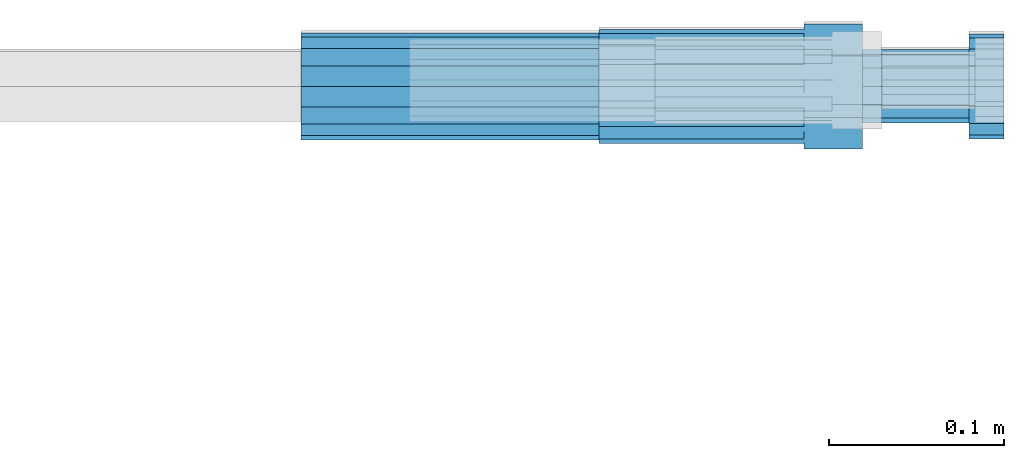
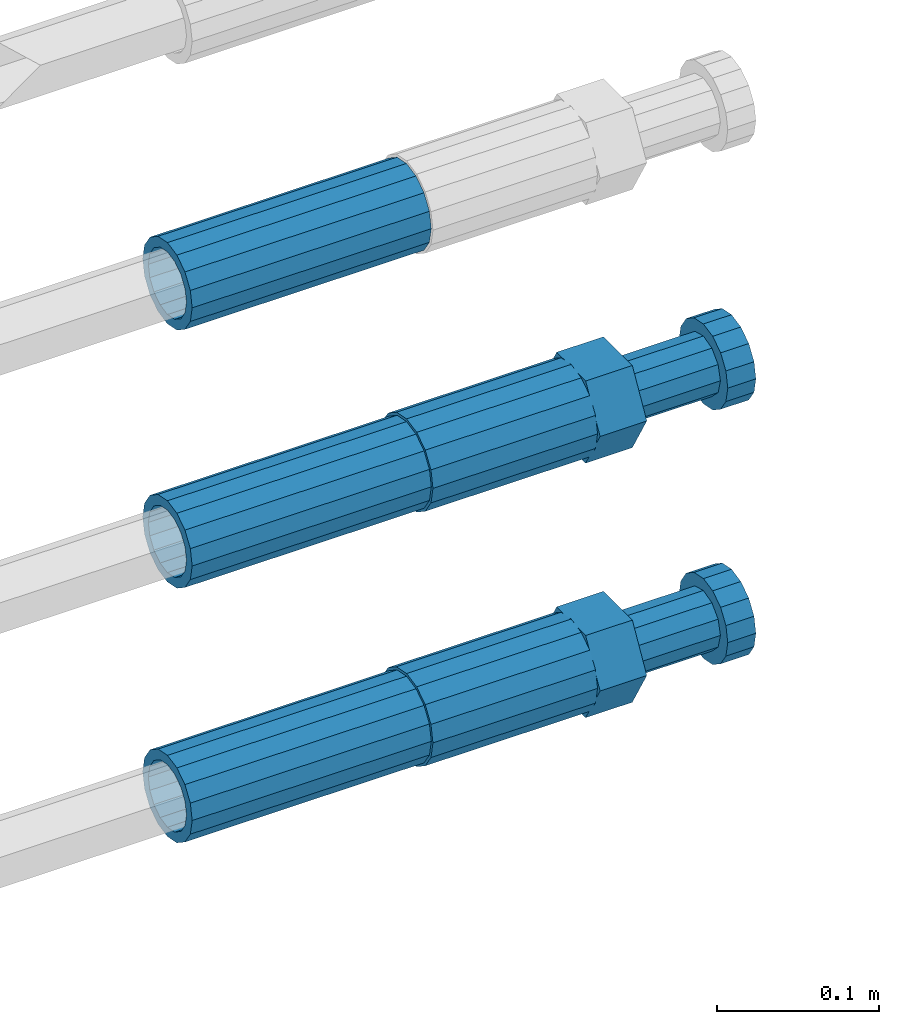
# One storey, part 115 of 119: 5 beams.
"""IFC2X3 building model written with IfcOpenShell, lengths in millimetres."""

from ifc_helpers import new_model, si_unit, frame, origin_with_axes, place, context, subcontext, project, spatial, faceted_brep, material, type_object, element, save


model = new_model("IFC2X3")

# Units and contexts
model_context = context("Model", 3, precision=1e-05, world=origin_with_axes())
body_context = subcontext(model_context, "Body", "Model", "MODEL_VIEW")
ifc_project = project(units=[si_unit("LENGTHUNIT", "METRE", prefix="MILLI"), si_unit("AREAUNIT", "SQUARE_METRE"), si_unit("VOLUMEUNIT", "CUBIC_METRE"), si_unit("MASSUNIT", "GRAM", prefix="KILO"), si_unit("TIMEUNIT", "SECOND"), si_unit("PLANEANGLEUNIT", "RADIAN"), si_unit("SOLIDANGLEUNIT", "STERADIAN"), si_unit("THERMODYNAMICTEMPERATUREUNIT", "DEGREE_CELSIUS"), si_unit("LUMINOUSINTENSITYUNIT", "LUMEN")], contexts=[model_context])

# Site, building, storey
site_placement = place(None, origin_with_axes())
site = spatial("IfcSite", under=ifc_project, at=site_placement, CompositionType="ELEMENT")
building_placement = place(site_placement, origin_with_axes())
building = spatial("IfcBuilding", under=site, at=building_placement, Name="Undefined", CompositionType="ELEMENT")
storey_placement = place(building_placement, origin_with_axes())
storey = spatial("IfcBuildingStorey", under=building, at=storey_placement, Name="Undefined", CompositionType="ELEMENT", Elevation=0.0)

# Beams
ifc_material = material(Name="STEEL/S275")
beam_type_1 = type_object("IfcBeamType", PredefinedType="NOTDEFINED")
beam_1_placement = place(storey_placement, frame((2039349.03023304, 6206399.98994599, 21049.6894122711), z_axis=(0.0, 0.0, 1.0), x_axis=(1.0, 0.0, 0.0)))
element("IfcBeam", 1, at=beam_1_placement, inside=storey, type_object=beam_type_1, material=ifc_material, Name="AG40N", context=body_context, shape_type="Brep", body=[
    faceted_brep([(1.62981450557709e-09, -23.4999999990687, 0.0), (7.45058059692383e-09, -21.7111690142192, 8.99306066057534), (170.000002125278, -21.711168999318, 8.99306066022245), (170.000002127141, -23.4999999844003, -3.66071617463604e-10), (4.65661287307739e-09, -16.6170093587134, 16.6170093578889), (170.000002122484, -16.6170093440451, 16.6170093575288), (1.86264514923096e-09, -8.99306066217832, 21.7111690140277), (170.000002118759, -8.99306064750999, 21.7111690136603), (2.3283064365387e-10, 9.31322574615479e-10, 23.5), (170.000002114102, 1.28056854009628e-08, 23.4999999996485), (-6.51925802230835e-09, 8.99306065868586, 21.7111690140241), (170.00000211224, 8.99306067335419, 21.7111690136639), (-7.45058059692383e-09, 16.6170093561523, 16.6170093578853), (170.000002109446, 16.6170093708206, 16.6170093575324), (-9.31322574615479e-09, 21.711169013055, 8.99306066057534), (170.000002108514, 21.7111690277234, 8.99306066022245), (-1.16415321826935e-09, 23.5000000009313, 0.0), (170.000002108514, 23.5000000144355, -3.66071617463604e-10), (-8.38190317153931e-09, 21.7111690151505, -8.99306066059444), (170.000002110377, 21.7111690300517, -8.9930606609546), (-5.58793544769287e-09, 16.6170093598776, -16.6170093579008), (170.000002113171, 16.6170093745459, -16.6170093582609), (-9.31322574615479e-10, 8.99306066334248, -21.7111690140396), (170.000002115965, 8.99306067801081, -21.7111690143961), (2.3283064365387e-10, 9.31322574615479e-10, -23.5), (170.00000211969, 1.7927959561348e-08, -23.5000000003843), (5.58793544769287e-09, -8.99306065752171, -21.7111690140396), (170.000002123415, -8.99306064285338, -21.7111690143961), (8.38190317153931e-09, -16.6170093549881, -16.6170093579008), (170.000002125278, -16.6170093403198, -16.6170093582646), (9.31322574615479e-09, -21.7111690121237, -8.99306066059444), (170.000002127141, -21.7111689972226, -8.9930606609546), (1.11758708953857e-08, -30.4999999990687, -9.54969436861575e-12), (1.30385160446167e-08, -28.1783257392235, -11.6718446871514), (170.000002129003, -28.1783257243223, -11.6718446875116), (170.000002129935, -30.4999999841675, -3.66071617463604e-10), (1.02445483207703e-08, -21.5667568228673, -21.5667568262129), (170.000002128072, -21.566756808199, -21.5667568265694), (7.45058059692383e-09, -11.6718446831219, -28.1783257416196), (170.000002125278, -11.6718446684536, -28.1783257419834), (3.72529029846191e-09, 3.95812094211578e-09, -30.5000000000277), (170.00000211969, 1.83936208486557e-08, -30.5000000003879), (-9.31322574615479e-10, 11.6718446905725, -28.1783257416232), (170.000002115965, 11.6718447052408, -28.1783257419797), (-6.51925802230835e-09, 21.5667568286881, -21.5667568262093), (170.000002110377, 21.5667568433564, -21.5667568265694), (-9.31322574615479e-09, 28.178325742716, -11.6718446871478), (170.000002108514, 28.1783257573843, -11.6718446875079), (-1.21071934700012e-08, 30.5, -5.91171556152403e-12), (170.000002106652, 30.5000000144355, -3.62433638656512e-10), (-1.21071934700012e-08, 28.1783257401548, 11.6718446871359), (170.00000210572, 28.1783257548232, 11.6718446867794), (-1.02445483207703e-08, 21.5667568240315, 21.5667568261974), (170.000002107583, 21.566756838467, 21.5667568258409), (-7.45058059692383e-09, 11.671844684286, 28.1783257416041), (170.000002110377, 11.6718446989544, 28.178325741244), (-2.79396772384644e-09, -2.56113708019257e-09, 30.5000000000159), (170.000002114102, 1.18743628263474e-08, 30.4999999996558), (1.86264514923096e-09, -11.6718446896411, 28.1783257416114), (170.000002118759, -11.67184467474, 28.178325741244), (7.45058059692383e-09, -21.5667568275239, 21.5667568261974), (170.000002123415, -21.5667568126228, 21.5667568258373), (1.02445483207703e-08, -28.1783257415518, 11.6718446871359), (170.000002127141, -28.1783257271163, 11.6718446867794)], [[[0, 1, 2, 3]], [[1, 4, 5, 2]], [[4, 6, 7, 5]], [[6, 8, 9, 7]], [[8, 10, 11, 9]], [[10, 12, 13, 11]], [[12, 14, 15, 13]], [[14, 16, 17, 15]], [[16, 18, 19, 17]], [[18, 20, 21, 19]], [[20, 22, 23, 21]], [[22, 24, 25, 23]], [[24, 26, 27, 25]], [[26, 28, 29, 27]], [[28, 30, 31, 29]], [[30, 0, 3, 31]], [[32, 33, 34, 35]], [[33, 36, 37, 34]], [[36, 38, 39, 37]], [[38, 40, 41, 39]], [[40, 42, 43, 41]], [[42, 44, 45, 43]], [[44, 46, 47, 45]], [[46, 48, 49, 47]], [[48, 50, 51, 49]], [[50, 52, 53, 51]], [[52, 54, 55, 53]], [[54, 56, 57, 55]], [[56, 58, 59, 57]], [[58, 60, 61, 59]], [[60, 62, 63, 61]], [[62, 32, 35, 63]], [[37, 39, 41, 43, 45, 47, 49, 51, 53, 55, 57, 59, 61, 63, 35, 34], [5, 7, 9, 11, 13, 15, 17, 19, 21, 23, 25, 27, 29, 31, 3, 2]], [[62, 60, 58, 56, 54, 52, 50, 48, 46, 44, 42, 40, 38, 36, 33, 32], [30, 28, 26, 24, 22, 20, 18, 16, 14, 12, 10, 8, 6, 4, 1, 0]]]),
])
beam_2_placement = place(storey_placement, frame((2039349.03023304, 6206399.98994599, 21240.9894122711), z_axis=(0.0, 0.0, 1.0), x_axis=(1.0, 0.0, 0.0)))
element("IfcBeam", 2, at=beam_2_placement, inside=storey, type_object=beam_type_1, material=ifc_material, Name="AG40N", context=body_context, shape_type="Brep", body=[
    faceted_brep([(1.62981450557709e-09, -23.4999999990687, 0.0), (7.45058059692383e-09, -21.7111690142192, 8.99306066057534), (170.000002125278, -21.711168999318, 8.99306066022245), (170.000002127141, -23.4999999844003, -3.66071617463604e-10), (4.65661287307739e-09, -16.6170093587134, 16.6170093578889), (170.000002122484, -16.6170093440451, 16.6170093575288), (1.86264514923096e-09, -8.99306066217832, 21.7111690140277), (170.000002118759, -8.99306064750999, 21.7111690136603), (2.3283064365387e-10, 9.31322574615479e-10, 23.5), (170.000002114102, 1.28056854009628e-08, 23.4999999996485), (-6.51925802230835e-09, 8.99306065868586, 21.7111690140241), (170.00000211224, 8.99306067335419, 21.7111690136639), (-7.45058059692383e-09, 16.6170093561523, 16.6170093578853), (170.000002109446, 16.6170093708206, 16.6170093575324), (-9.31322574615479e-09, 21.711169013055, 8.99306066057534), (170.000002108514, 21.7111690277234, 8.99306066022245), (-1.16415321826935e-09, 23.5000000009313, 0.0), (170.000002108514, 23.5000000144355, -3.66071617463604e-10), (-8.38190317153931e-09, 21.7111690151505, -8.99306066059444), (170.000002110377, 21.7111690300517, -8.9930606609546), (-5.58793544769287e-09, 16.6170093598776, -16.6170093579008), (170.000002113171, 16.6170093745459, -16.6170093582609), (-9.31322574615479e-10, 8.99306066334248, -21.7111690140396), (170.000002115965, 8.99306067801081, -21.7111690143961), (2.3283064365387e-10, 9.31322574615479e-10, -23.5), (170.00000211969, 1.7927959561348e-08, -23.5000000003843), (5.58793544769287e-09, -8.99306065752171, -21.7111690140396), (170.000002123415, -8.99306064285338, -21.7111690143961), (8.38190317153931e-09, -16.6170093549881, -16.6170093579008), (170.000002125278, -16.6170093403198, -16.6170093582646), (9.31322574615479e-09, -21.7111690121237, -8.99306066059444), (170.000002127141, -21.7111689972226, -8.9930606609546), (1.11758708953857e-08, -30.4999999990687, -9.54969436861575e-12), (1.30385160446167e-08, -28.1783257392235, -11.6718446871514), (170.000002129003, -28.1783257243223, -11.6718446875116), (170.000002129935, -30.4999999841675, -3.66071617463604e-10), (1.02445483207703e-08, -21.5667568228673, -21.5667568262129), (170.000002128072, -21.566756808199, -21.5667568265694), (7.45058059692383e-09, -11.6718446831219, -28.1783257416196), (170.000002125278, -11.6718446684536, -28.1783257419834), (3.72529029846191e-09, 3.95812094211578e-09, -30.5000000000277), (170.00000211969, 1.83936208486557e-08, -30.5000000003879), (-9.31322574615479e-10, 11.6718446905725, -28.1783257416232), (170.000002115965, 11.6718447052408, -28.1783257419797), (-6.51925802230835e-09, 21.5667568286881, -21.5667568262093), (170.000002110377, 21.5667568433564, -21.5667568265694), (-9.31322574615479e-09, 28.178325742716, -11.6718446871478), (170.000002108514, 28.1783257573843, -11.6718446875079), (-1.21071934700012e-08, 30.5, -5.91171556152403e-12), (170.000002106652, 30.5000000144355, -3.62433638656512e-10), (-1.21071934700012e-08, 28.1783257401548, 11.6718446871359), (170.00000210572, 28.1783257548232, 11.6718446867794), (-1.02445483207703e-08, 21.5667568240315, 21.5667568261974), (170.000002107583, 21.566756838467, 21.5667568258409), (-7.45058059692383e-09, 11.671844684286, 28.1783257416041), (170.000002110377, 11.6718446989544, 28.178325741244), (-2.79396772384644e-09, -2.56113708019257e-09, 30.5000000000159), (170.000002114102, 1.18743628263474e-08, 30.4999999996558), (1.86264514923096e-09, -11.6718446896411, 28.1783257416114), (170.000002118759, -11.67184467474, 28.178325741244), (7.45058059692383e-09, -21.5667568275239, 21.5667568261974), (170.000002123415, -21.5667568126228, 21.5667568258373), (1.02445483207703e-08, -28.1783257415518, 11.6718446871359), (170.000002127141, -28.1783257271163, 11.6718446867794)], [[[0, 1, 2, 3]], [[1, 4, 5, 2]], [[4, 6, 7, 5]], [[6, 8, 9, 7]], [[8, 10, 11, 9]], [[10, 12, 13, 11]], [[12, 14, 15, 13]], [[14, 16, 17, 15]], [[16, 18, 19, 17]], [[18, 20, 21, 19]], [[20, 22, 23, 21]], [[22, 24, 25, 23]], [[24, 26, 27, 25]], [[26, 28, 29, 27]], [[28, 30, 31, 29]], [[30, 0, 3, 31]], [[32, 33, 34, 35]], [[33, 36, 37, 34]], [[36, 38, 39, 37]], [[38, 40, 41, 39]], [[40, 42, 43, 41]], [[42, 44, 45, 43]], [[44, 46, 47, 45]], [[46, 48, 49, 47]], [[48, 50, 51, 49]], [[50, 52, 53, 51]], [[52, 54, 55, 53]], [[54, 56, 57, 55]], [[56, 58, 59, 57]], [[58, 60, 61, 59]], [[60, 62, 63, 61]], [[62, 32, 35, 63]], [[37, 39, 41, 43, 45, 47, 49, 51, 53, 55, 57, 59, 61, 63, 35, 34], [5, 7, 9, 11, 13, 15, 17, 19, 21, 23, 25, 27, 29, 31, 3, 2]], [[62, 60, 58, 56, 54, 52, 50, 48, 46, 44, 42, 40, 38, 36, 33, 32], [30, 28, 26, 24, 22, 20, 18, 16, 14, 12, 10, 8, 6, 4, 1, 0]]]),
])
beam_3_placement = place(storey_placement, frame((2039349.03023304, 6206399.98994599, 21434.9894122711), z_axis=(0.0, 0.0, 1.0), x_axis=(1.0, 0.0, 0.0)))
element("IfcBeam", 3, at=beam_3_placement, inside=storey, type_object=beam_type_1, material=ifc_material, Name="AG40N", context=body_context, shape_type="Brep", body=[
    faceted_brep([(1.62981450557709e-09, -23.4999999990687, 0.0), (7.45058059692383e-09, -21.7111690142192, 8.99306066057534), (170.000002125278, -21.711168999318, 8.99306066022245), (170.000002127141, -23.4999999844003, -3.66071617463604e-10), (4.65661287307739e-09, -16.6170093587134, 16.6170093578889), (170.000002122484, -16.6170093440451, 16.6170093575288), (1.86264514923096e-09, -8.99306066217832, 21.7111690140277), (170.000002118759, -8.99306064750999, 21.7111690136603), (2.3283064365387e-10, 9.31322574615479e-10, 23.5), (170.000002114102, 1.28056854009628e-08, 23.4999999996485), (-6.51925802230835e-09, 8.99306065868586, 21.7111690140241), (170.00000211224, 8.99306067335419, 21.7111690136639), (-7.45058059692383e-09, 16.6170093561523, 16.6170093578853), (170.000002109446, 16.6170093708206, 16.6170093575324), (-9.31322574615479e-09, 21.711169013055, 8.99306066057534), (170.000002108514, 21.7111690277234, 8.99306066022245), (-1.16415321826935e-09, 23.5000000009313, 0.0), (170.000002108514, 23.5000000144355, -3.66071617463604e-10), (-8.38190317153931e-09, 21.7111690151505, -8.99306066059444), (170.000002110377, 21.7111690300517, -8.9930606609546), (-5.58793544769287e-09, 16.6170093598776, -16.6170093579008), (170.000002113171, 16.6170093745459, -16.6170093582609), (-9.31322574615479e-10, 8.99306066334248, -21.7111690140396), (170.000002115965, 8.99306067801081, -21.7111690143961), (2.3283064365387e-10, 9.31322574615479e-10, -23.5), (170.00000211969, 1.7927959561348e-08, -23.5000000003843), (5.58793544769287e-09, -8.99306065752171, -21.7111690140396), (170.000002123415, -8.99306064285338, -21.7111690143961), (8.38190317153931e-09, -16.6170093549881, -16.6170093579008), (170.000002125278, -16.6170093403198, -16.6170093582646), (9.31322574615479e-09, -21.7111690121237, -8.99306066059444), (170.000002127141, -21.7111689972226, -8.9930606609546), (1.11758708953857e-08, -30.4999999990687, -9.54969436861575e-12), (1.30385160446167e-08, -28.1783257392235, -11.6718446871514), (170.000002129003, -28.1783257243223, -11.6718446875116), (170.000002129935, -30.4999999841675, -3.66071617463604e-10), (1.02445483207703e-08, -21.5667568228673, -21.5667568262129), (170.000002128072, -21.566756808199, -21.5667568265694), (7.45058059692383e-09, -11.6718446831219, -28.1783257416196), (170.000002125278, -11.6718446684536, -28.1783257419834), (3.72529029846191e-09, 3.95812094211578e-09, -30.5000000000277), (170.00000211969, 1.83936208486557e-08, -30.5000000003879), (-9.31322574615479e-10, 11.6718446905725, -28.1783257416232), (170.000002115965, 11.6718447052408, -28.1783257419797), (-6.51925802230835e-09, 21.5667568286881, -21.5667568262093), (170.000002110377, 21.5667568433564, -21.5667568265694), (-9.31322574615479e-09, 28.178325742716, -11.6718446871478), (170.000002108514, 28.1783257573843, -11.6718446875079), (-1.21071934700012e-08, 30.5, -5.91171556152403e-12), (170.000002106652, 30.5000000144355, -3.62433638656512e-10), (-1.21071934700012e-08, 28.1783257401548, 11.6718446871359), (170.00000210572, 28.1783257548232, 11.6718446867794), (-1.02445483207703e-08, 21.5667568240315, 21.5667568261974), (170.000002107583, 21.566756838467, 21.5667568258409), (-7.45058059692383e-09, 11.671844684286, 28.1783257416041), (170.000002110377, 11.6718446989544, 28.178325741244), (-2.79396772384644e-09, -2.56113708019257e-09, 30.5000000000159), (170.000002114102, 1.18743628263474e-08, 30.4999999996558), (1.86264514923096e-09, -11.6718446896411, 28.1783257416114), (170.000002118759, -11.67184467474, 28.178325741244), (7.45058059692383e-09, -21.5667568275239, 21.5667568261974), (170.000002123415, -21.5667568126228, 21.5667568258373), (1.02445483207703e-08, -28.1783257415518, 11.6718446871359), (170.000002127141, -28.1783257271163, 11.6718446867794)], [[[0, 1, 2, 3]], [[1, 4, 5, 2]], [[4, 6, 7, 5]], [[6, 8, 9, 7]], [[8, 10, 11, 9]], [[10, 12, 13, 11]], [[12, 14, 15, 13]], [[14, 16, 17, 15]], [[16, 18, 19, 17]], [[18, 20, 21, 19]], [[20, 22, 23, 21]], [[22, 24, 25, 23]], [[24, 26, 27, 25]], [[26, 28, 29, 27]], [[28, 30, 31, 29]], [[30, 0, 3, 31]], [[32, 33, 34, 35]], [[33, 36, 37, 34]], [[36, 38, 39, 37]], [[38, 40, 41, 39]], [[40, 42, 43, 41]], [[42, 44, 45, 43]], [[44, 46, 47, 45]], [[46, 48, 49, 47]], [[48, 50, 51, 49]], [[50, 52, 53, 51]], [[52, 54, 55, 53]], [[54, 56, 57, 55]], [[56, 58, 59, 57]], [[58, 60, 61, 59]], [[60, 62, 63, 61]], [[62, 32, 35, 63]], [[37, 39, 41, 43, 45, 47, 49, 51, 53, 55, 57, 59, 61, 63, 35, 34], [5, 7, 9, 11, 13, 15, 17, 19, 21, 23, 25, 27, 29, 31, 3, 2]], [[62, 60, 58, 56, 54, 52, 50, 48, 46, 44, 42, 40, 38, 36, 33, 32], [30, 28, 26, 24, 22, 20, 18, 16, 14, 12, 10, 8, 6, 4, 1, 0]]]),
])
beam_type_2 = type_object("IfcBeamType", Name="ROD65", PredefinedType="NOTDEFINED")
beam_4_placement = place(storey_placement, frame((2039519.03023304, 6206399.98994599, 21049.6894143674), z_axis=(0.0, 0.0, 1.0), x_axis=(1.0, 0.0, 0.0)))
element("IfcBeam", 4, at=beam_4_placement, inside=storey, type_object=beam_type_2, material=ifc_material, Name="AGB40", ObjectType="ROD65", context=body_context, shape_type="Brep", body=[
    faceted_brep([(116.999999999069, 17.8249999252148, 30.8738056446964), (116.999999998137, 22.0056957420893, 23.632628078838), (116.999999999069, 12.4372115600854, 30.0260848066173), (116.999999999069, 8.17543111252598, 30.8738056446964), (117.000000000931, -17.8250000746921, 30.8738056446964), (150.200000001118, -17.8250000723638, 30.8738056446964), (150.199999999255, 17.8249999275431, 30.8738056446964), (117.000000000931, -8.17543109622784, 30.8738056446964), (117.000000001863, -22.0056959956419, 23.6326278985034), (117.000000000931, -12.4372115437873, 30.0260848066173), (117.000000001863, -35.6500000746455, -2.18278728425503e-10), (150.200000002049, -35.6500000723172, -2.18278728425503e-10), (117.000000001863, -30.8443149488885, 8.32369080289209), (117.000000001863, -30.8443149488885, -8.32369080355784), (117.000000002794, -32.4999999918509, 0.0), (117.000000000931, -17.8250000746921, -30.873805645133), (150.200000001118, -17.8250000723638, -30.873805645133), (117.000000001863, -22.0056959961075, -23.6326278982269), (117.000000000931, -8.17543109389953, -30.873805645133), (117.000000000931, -12.4372115437873, -30.0260848066173), (116.999999999069, 17.8249999252148, -30.873805645133), (150.199999999255, 17.8249999275431, -30.873805645133), (116.999999999069, 8.17543111019768, -30.873805645133), (116.999999999069, 12.4372115600854, -30.0260848066173), (116.999999998137, 22.005695742555, -23.6326280785652), (116.999999998137, 35.6499999251682, -2.18278728425503e-10), (150.199999998324, 35.6499999277294, -2.18278728425503e-10), (116.999999998137, 30.8443150522653, -8.32369036550881), (116.999999997206, 32.5000000081491, 0.0), (116.999999998137, 30.8443150522653, 8.32369036483942), (1.86264514923096e-09, -22.9809703885112, 22.9809703885621), (1.86264514923096e-09, -30.0260848065373, 12.4372115518672), (117.000000001863, -30.0260847983882, 12.4372115518672), (117.000000001863, -22.9809703803621, 22.9809703885621), (-1.86264514923096e-09, 22.9809703885112, -22.9809703885621), (-1.86264514923096e-09, 30.0260848065373, -12.4372115518672), (116.999999998137, 30.0260848146863, -12.4372115518672), (116.999999998137, 22.9809703966603, -22.9809703885621), (1.86264514923096e-09, -30.0260848065373, -12.4372115518672), (1.86264514923096e-09, -22.9809703885112, -22.9809703885621), (117.000000001863, -22.9809703803621, -22.9809703885621), (117.000000001863, -30.0260847983882, -12.4372115518672), (9.31322574615479e-10, -12.4372115519363, 30.0260848066173), (0.0, 0.0, 32.5), (-9.31322574615479e-10, 12.4372115519363, 30.0260848066173), (-1.86264514923096e-09, 22.9809703885112, 22.9809703885621), (-1.86264514923096e-09, 30.0260848065373, 12.4372115518672), (-2.79396772384644e-09, 32.5, 0.0), (-9.31322574615479e-10, 12.4372115519363, -30.0260848066173), (0.0, 0.0, -32.5), (9.31322574615479e-10, -12.4372115519363, -30.0260848066173), (2.79396772384644e-09, -32.5, 0.0), (116.999999998137, 22.9809703966603, 22.9809703885621), (116.999999998137, 30.0260848146863, 12.4372115518672), (117.0, 8.14907252788544e-09, -32.5), (117.0, 8.14907252788544e-09, 32.5), (150.200000000186, -10.5000000959262, 18.1865334791873), (150.199999999255, -9.59262251853943e-08, 20.9999999997126), (150.199999998324, 10.4999999040738, 18.1865334791873), (150.199999997392, 18.1865333835594, 10.4999999997126), (150.199999997392, 20.9999999040738, -2.87400325760245e-10), (150.199999997392, 18.1865333835594, -10.5000000002874), (150.199999998324, 10.4999999040738, -18.1865334797621), (150.199999999255, -9.59262251853943e-08, -21.0000000002874), (150.200000000186, -10.5000000959262, -18.1865334797621), (150.200000000186, -18.1865335754119, -10.5000000002874), (150.200000001118, -21.0000000959262, -2.87400325760245e-10), (150.200000000186, -18.1865335754119, 10.4999999997126), (210.979999999516, 10.4999999082647, 18.1865334791873), (210.979999999516, -9.17352735996246e-08, 20.9999999997126), (210.979999997653, 18.1865333877504, 10.4999999997126), (210.979999997653, 20.9999999082647, -2.87400325760245e-10), (210.979999997653, 18.1865333877504, -10.5000000002874), (210.979999999516, 10.4999999082647, -18.1865334797621), (210.979999999516, -9.17352735996246e-08, -21.0000000002874), (210.979999999516, -10.5000000917353, -18.1865334797621), (210.980000000447, -18.1865335712209, -10.5000000002874), (210.980000001378, -21.0000000917353, -2.87400325760245e-10), (210.980000000447, -18.1865335712209, 10.4999999997126), (210.979999999516, -10.5000000917353, 18.1865334791873), (211.001368402503, -27.7269939335529, -11.4911163272045), (211.003082515672, -21.2238095656503, -21.2238154190527), (231.002518340945, -21.2131946226582, -21.2132004554769), (231.000804228708, -27.7163789905608, -11.4805013636287), (211.001368415542, -11.4911086384673, -27.7269970399575), (231.000804241747, -11.4804936954752, -27.7163820763781), (210.996487061493, -0.0106066407170147, -30.0106107396168), (230.995922887698, 8.30227509140968e-06, -29.999995776041), (210.98918159306, 11.4698940692469, -27.7269970332745), (230.988617419265, 11.4805090120062, -27.7163820696951), (210.980564201251, 21.2025913291145, -21.2238154067054), (230.980000027455, 21.2132062721066, -21.2132004431296), (210.971946807578, 27.7057702087332, -11.4911163110701), (230.971382633783, 27.7163851517253, -11.4805013474943), (210.964641331695, 29.9893806746695, -0.0106149565435771), (230.9640771579, 29.9999956176616, 7.03221303410828e-09), (210.959759964608, 27.7057637346443, 11.4698863966551), (230.959195790812, 27.7163786776364, 11.4805013602345), (210.958045851439, 21.2025793667417, 21.2025854885032), (230.957481677644, 21.2131943097338, 21.2132004520827), (210.959759951569, 11.4698784395587, 27.705767109408), (230.959195776843, 11.4804933823179, 27.7163820729838), (210.964641305618, -0.0106235581915826, 29.9893808090674), (230.964077131823, -8.61519947648048e-06, 29.9999957726432), (210.971946774051, -11.4911242681555, 27.7057671027251), (230.971382599324, -11.4805093251634, 27.7163820663009), (210.98056416586, -21.2238215280231, 21.2025854761559), (230.979999991134, -21.2132065852638, 21.2132004397354), (210.989181559533, -27.7270004076418, 11.4698863805206), (230.988617384806, -27.7163854646496, 11.4805013441), (210.996487035416, -30.0106108735781, -0.0106149740058754), (230.995922861621, -29.999995930586, -1.04300852399319e-08)], [[[0, 1, 2, 3]], [[4, 5, 6, 0, 3, 7]], [[8, 4, 7, 9]], [[10, 11, 5, 4, 8, 12]], [[13, 10, 12, 14]], [[15, 16, 11, 10, 13, 17]], [[18, 15, 17, 19]], [[20, 21, 16, 15, 18, 22]], [[20, 22, 23, 24]], [[25, 26, 21, 20, 24, 27]], [[25, 27, 28, 29]], [[30, 31, 32, 33]], [[34, 35, 36, 37]], [[38, 39, 40, 41]], [[31, 30, 42, 43, 44, 45, 46, 47, 35, 34, 48, 49, 50, 39, 38, 51]], [[46, 45, 52, 53]], [[28, 47, 46, 53, 29]], [[27, 36, 35, 47, 28]], [[24, 37, 36, 27]], [[23, 48, 34, 37, 24]], [[22, 54, 49, 48, 23]], [[18, 54, 22]], [[19, 50, 49, 54, 18]], [[17, 40, 39, 50, 19]], [[13, 41, 40, 17]], [[14, 51, 38, 41, 13]], [[12, 32, 31, 51, 14]], [[8, 33, 32, 12]], [[9, 42, 30, 33, 8]], [[7, 55, 43, 42, 9]], [[3, 55, 7]], [[2, 44, 43, 55, 3]], [[1, 52, 45, 44, 2]], [[29, 53, 52, 1]], [[0, 6, 26, 25, 29, 1]], [[5, 11, 16, 21, 26, 6], [56, 57, 58, 59, 60, 61, 62, 63, 64, 65, 66, 67]], [[68, 58, 57, 69]], [[70, 59, 58, 68]], [[71, 60, 59, 70]], [[72, 61, 60, 71]], [[73, 62, 61, 72]], [[74, 63, 62, 73]], [[75, 64, 63, 74]], [[76, 65, 64, 75]], [[77, 66, 65, 76]], [[78, 67, 66, 77]], [[79, 56, 67, 78]], [[69, 57, 56, 79]], [[80, 81, 82, 83]], [[81, 84, 85, 82]], [[84, 86, 87, 85]], [[86, 88, 89, 87]], [[88, 90, 91, 89]], [[90, 92, 93, 91]], [[92, 94, 95, 93]], [[94, 96, 97, 95]], [[96, 98, 99, 97]], [[98, 100, 101, 99]], [[100, 102, 103, 101]], [[102, 104, 105, 103]], [[104, 106, 107, 105]], [[106, 108, 109, 107]], [[108, 110, 111, 109]], [[82, 85, 87, 89, 91, 93, 95, 97, 99, 101, 103, 105, 107, 109, 111, 83]], [[110, 80, 83, 111]], [[108, 106, 104, 102, 100, 98, 96, 94, 92, 90, 88, 86, 84, 81, 80, 110], [78, 77, 76, 75, 74, 73, 72, 71, 70, 68, 69, 79]]]),
])
beam_5_placement = place(storey_placement, frame((2039519.03023304, 6206399.98994599, 21240.9894143674), z_axis=(0.0, 0.0, 1.0), x_axis=(1.0, 0.0, 0.0)))
element("IfcBeam", 5, at=beam_5_placement, inside=storey, type_object=beam_type_2, material=ifc_material, Name="AGB40", ObjectType="ROD65", context=body_context, shape_type="Brep", body=[
    faceted_brep([(116.999999999069, 17.8249999252148, 30.8738056446964), (116.999999998137, 22.0056957420893, 23.632628078838), (116.999999999069, 12.4372115600854, 30.0260848066173), (116.999999999069, 8.17543111252598, 30.8738056446964), (117.000000000931, -17.8250000746921, 30.8738056446964), (150.200000001118, -17.8250000723638, 30.8738056446964), (150.199999999255, 17.8249999275431, 30.8738056446964), (117.000000000931, -8.17543109622784, 30.8738056446964), (117.000000001863, -22.0056959956419, 23.6326278985034), (117.000000000931, -12.4372115437873, 30.0260848066173), (117.000000001863, -35.6500000746455, -2.18278728425503e-10), (150.200000002049, -35.6500000723172, -2.18278728425503e-10), (117.000000001863, -30.8443149488885, 8.32369080289209), (117.000000001863, -30.8443149488885, -8.32369080355784), (117.000000002794, -32.4999999918509, 0.0), (117.000000000931, -17.8250000746921, -30.873805645133), (150.200000001118, -17.8250000723638, -30.873805645133), (117.000000001863, -22.0056959961075, -23.6326278982269), (117.000000000931, -8.17543109389953, -30.873805645133), (117.000000000931, -12.4372115437873, -30.0260848066173), (116.999999999069, 17.8249999252148, -30.873805645133), (150.199999999255, 17.8249999275431, -30.873805645133), (116.999999999069, 8.17543111019768, -30.873805645133), (116.999999999069, 12.4372115600854, -30.0260848066173), (116.999999998137, 22.005695742555, -23.6326280785652), (116.999999998137, 35.6499999251682, -2.18278728425503e-10), (150.199999998324, 35.6499999277294, -2.18278728425503e-10), (116.999999998137, 30.8443150522653, -8.32369036550881), (116.999999997206, 32.5000000081491, 0.0), (116.999999998137, 30.8443150522653, 8.32369036483942), (1.86264514923096e-09, -22.9809703885112, 22.9809703885621), (1.86264514923096e-09, -30.0260848065373, 12.4372115518672), (117.000000001863, -30.0260847983882, 12.4372115518672), (117.000000001863, -22.9809703803621, 22.9809703885621), (-1.86264514923096e-09, 22.9809703885112, -22.9809703885621), (-1.86264514923096e-09, 30.0260848065373, -12.4372115518672), (116.999999998137, 30.0260848146863, -12.4372115518672), (116.999999998137, 22.9809703966603, -22.9809703885621), (1.86264514923096e-09, -30.0260848065373, -12.4372115518672), (1.86264514923096e-09, -22.9809703885112, -22.9809703885621), (117.000000001863, -22.9809703803621, -22.9809703885621), (117.000000001863, -30.0260847983882, -12.4372115518672), (9.31322574615479e-10, -12.4372115519363, 30.0260848066173), (0.0, 0.0, 32.5), (-9.31322574615479e-10, 12.4372115519363, 30.0260848066173), (-1.86264514923096e-09, 22.9809703885112, 22.9809703885621), (-1.86264514923096e-09, 30.0260848065373, 12.4372115518672), (-2.79396772384644e-09, 32.5, 0.0), (-9.31322574615479e-10, 12.4372115519363, -30.0260848066173), (0.0, 0.0, -32.5), (9.31322574615479e-10, -12.4372115519363, -30.0260848066173), (2.79396772384644e-09, -32.5, 0.0), (116.999999998137, 22.9809703966603, 22.9809703885621), (116.999999998137, 30.0260848146863, 12.4372115518672), (117.0, 8.14907252788544e-09, -32.5), (117.0, 8.14907252788544e-09, 32.5), (150.200000000186, -10.5000000959262, 18.1865334791873), (150.199999999255, -9.59262251853943e-08, 20.9999999997126), (150.199999998324, 10.4999999040738, 18.1865334791873), (150.199999997392, 18.1865333835594, 10.4999999997126), (150.199999997392, 20.9999999040738, -2.87400325760245e-10), (150.199999997392, 18.1865333835594, -10.5000000002874), (150.199999998324, 10.4999999040738, -18.1865334797621), (150.199999999255, -9.59262251853943e-08, -21.0000000002874), (150.200000000186, -10.5000000959262, -18.1865334797621), (150.200000000186, -18.1865335754119, -10.5000000002874), (150.200000001118, -21.0000000959262, -2.87400325760245e-10), (150.200000000186, -18.1865335754119, 10.4999999997126), (210.979999999516, 10.4999999082647, 18.1865334791873), (210.979999999516, -9.17352735996246e-08, 20.9999999997126), (210.979999997653, 18.1865333877504, 10.4999999997126), (210.979999997653, 20.9999999082647, -2.87400325760245e-10), (210.979999997653, 18.1865333877504, -10.5000000002874), (210.979999999516, 10.4999999082647, -18.1865334797621), (210.979999999516, -9.17352735996246e-08, -21.0000000002874), (210.979999999516, -10.5000000917353, -18.1865334797621), (210.980000000447, -18.1865335712209, -10.5000000002874), (210.980000001378, -21.0000000917353, -2.87400325760245e-10), (210.980000000447, -18.1865335712209, 10.4999999997126), (210.979999999516, -10.5000000917353, 18.1865334791873), (211.001368402503, -27.7269939335529, -11.4911163272045), (211.003082515672, -21.2238095656503, -21.2238154190527), (231.002518340945, -21.2131946226582, -21.2132004554769), (231.000804228708, -27.7163789905608, -11.4805013636287), (211.001368415542, -11.4911086384673, -27.7269970399575), (231.000804241747, -11.4804936954752, -27.7163820763781), (210.996487061493, -0.0106066407170147, -30.0106107396168), (230.995922887698, 8.30227509140968e-06, -29.999995776041), (210.98918159306, 11.4698940692469, -27.7269970332745), (230.988617419265, 11.4805090120062, -27.7163820696951), (210.980564201251, 21.2025913291145, -21.2238154067054), (230.980000027455, 21.2132062721066, -21.2132004431296), (210.971946807578, 27.7057702087332, -11.4911163110701), (230.971382633783, 27.7163851517253, -11.4805013474943), (210.964641331695, 29.9893806746695, -0.0106149565435771), (230.9640771579, 29.9999956176616, 7.03221303410828e-09), (210.959759964608, 27.7057637346443, 11.4698863966551), (230.959195790812, 27.7163786776364, 11.4805013602345), (210.958045851439, 21.2025793667417, 21.2025854885032), (230.957481677644, 21.2131943097338, 21.2132004520827), (210.959759951569, 11.4698784395587, 27.705767109408), (230.959195776843, 11.4804933823179, 27.7163820729838), (210.964641305618, -0.0106235581915826, 29.9893808090674), (230.964077131823, -8.61519947648048e-06, 29.9999957726432), (210.971946774051, -11.4911242681555, 27.7057671027251), (230.971382599324, -11.4805093251634, 27.7163820663009), (210.98056416586, -21.2238215280231, 21.2025854761559), (230.979999991134, -21.2132065852638, 21.2132004397354), (210.989181559533, -27.7270004076418, 11.4698863805206), (230.988617384806, -27.7163854646496, 11.4805013441), (210.996487035416, -30.0106108735781, -0.0106149740058754), (230.995922861621, -29.999995930586, -1.04300852399319e-08)], [[[0, 1, 2, 3]], [[4, 5, 6, 0, 3, 7]], [[8, 4, 7, 9]], [[10, 11, 5, 4, 8, 12]], [[13, 10, 12, 14]], [[15, 16, 11, 10, 13, 17]], [[18, 15, 17, 19]], [[20, 21, 16, 15, 18, 22]], [[20, 22, 23, 24]], [[25, 26, 21, 20, 24, 27]], [[25, 27, 28, 29]], [[30, 31, 32, 33]], [[34, 35, 36, 37]], [[38, 39, 40, 41]], [[31, 30, 42, 43, 44, 45, 46, 47, 35, 34, 48, 49, 50, 39, 38, 51]], [[46, 45, 52, 53]], [[28, 47, 46, 53, 29]], [[27, 36, 35, 47, 28]], [[24, 37, 36, 27]], [[23, 48, 34, 37, 24]], [[22, 54, 49, 48, 23]], [[18, 54, 22]], [[19, 50, 49, 54, 18]], [[17, 40, 39, 50, 19]], [[13, 41, 40, 17]], [[14, 51, 38, 41, 13]], [[12, 32, 31, 51, 14]], [[8, 33, 32, 12]], [[9, 42, 30, 33, 8]], [[7, 55, 43, 42, 9]], [[3, 55, 7]], [[2, 44, 43, 55, 3]], [[1, 52, 45, 44, 2]], [[29, 53, 52, 1]], [[0, 6, 26, 25, 29, 1]], [[5, 11, 16, 21, 26, 6], [56, 57, 58, 59, 60, 61, 62, 63, 64, 65, 66, 67]], [[68, 58, 57, 69]], [[70, 59, 58, 68]], [[71, 60, 59, 70]], [[72, 61, 60, 71]], [[73, 62, 61, 72]], [[74, 63, 62, 73]], [[75, 64, 63, 74]], [[76, 65, 64, 75]], [[77, 66, 65, 76]], [[78, 67, 66, 77]], [[79, 56, 67, 78]], [[69, 57, 56, 79]], [[80, 81, 82, 83]], [[81, 84, 85, 82]], [[84, 86, 87, 85]], [[86, 88, 89, 87]], [[88, 90, 91, 89]], [[90, 92, 93, 91]], [[92, 94, 95, 93]], [[94, 96, 97, 95]], [[96, 98, 99, 97]], [[98, 100, 101, 99]], [[100, 102, 103, 101]], [[102, 104, 105, 103]], [[104, 106, 107, 105]], [[106, 108, 109, 107]], [[108, 110, 111, 109]], [[82, 85, 87, 89, 91, 93, 95, 97, 99, 101, 103, 105, 107, 109, 111, 83]], [[110, 80, 83, 111]], [[108, 106, 104, 102, 100, 98, 96, 94, 92, 90, 88, 86, 84, 81, 80, 110], [78, 77, 76, 75, 74, 73, 72, 71, 70, 68, 69, 79]]]),
])

save(model, "model.ifc")
